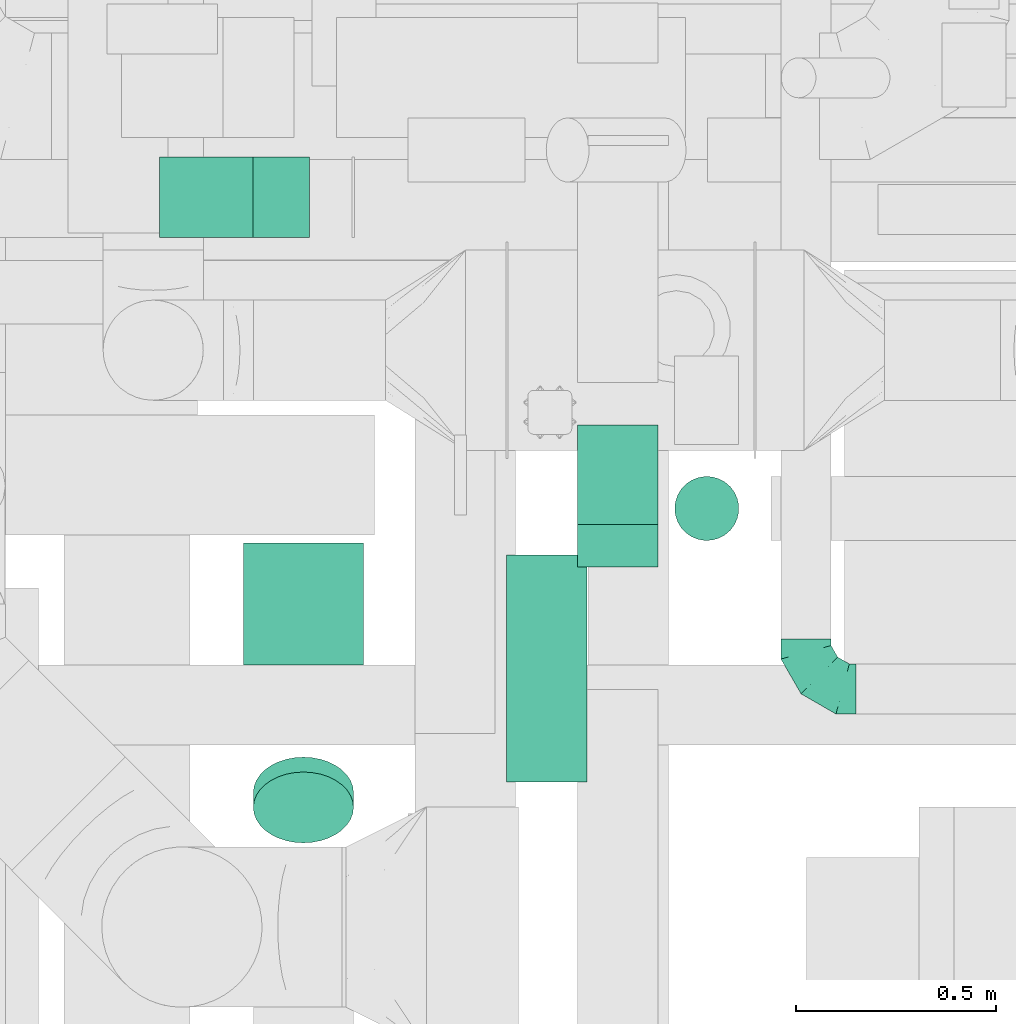
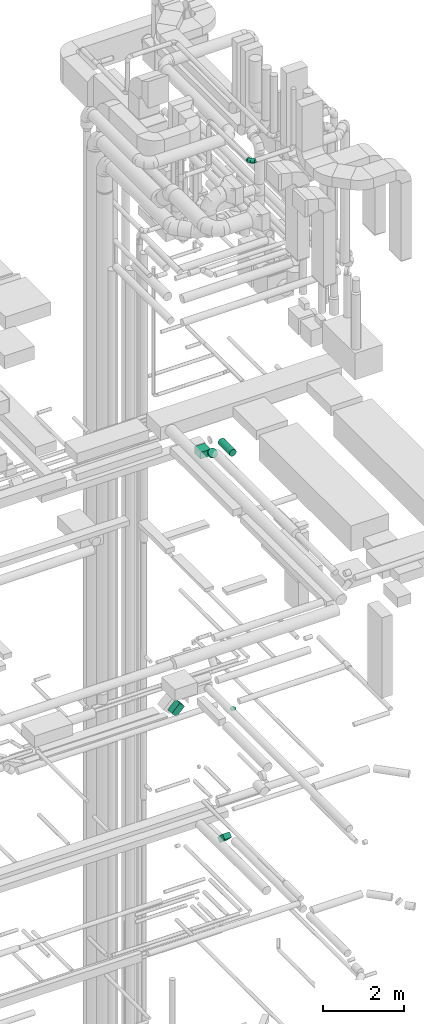
# One storey, part 258 of 337: 6 flow segments, 1 flow fitting.
"""IFC2X3 building model written with IfcOpenShell, lengths in millimetres."""

import ifcopenshell
import ifcopenshell.guid

model = None  # the IFC model being written
_history = None  # IfcOwnerHistory: only IFC2X3 demands one
_inside = {}  # id of a spatial element -> (the spatial element, [elements in it])
_under = {}  # id of a project, library or spatial element -> (it, [spatial elements below it])
_declared = {}  # id of a project -> (the project, [libraries it declares])
_typed = {}  # id of a type object -> (the type object, [elements of that type])
_made_of = {}  # id of a material, layer set ... -> (it, [elements and type objects made of it])


def new_model(schema):
    """Start an empty IFC model of exactly this schema.

    Asked for "IFC4X3", IfcOpenShell would pick the latest addendum, in which some entities
    have other attributes; the version numbers below select the first issue.
    IFC2X3 requires an IfcOwnerHistory on every rooted entity: one is made here for all.
    """
    global model, _history
    if schema == "IFC4X3":
        model = ifcopenshell.file(schema_version=(4, 3, 0, 0))
    else:
        model = ifcopenshell.file(schema=schema)
    _inside.clear()
    _under.clear()
    _declared.clear()
    _typed.clear()
    _made_of.clear()
    _history = None
    if model.schema == "IFC2X3":
        org = make("IfcOrganization", Name="unknown")
        user = make(
            "IfcPersonAndOrganization",
            ThePerson=make("IfcPerson", FamilyName="unknown"),
            TheOrganization=org,
        )
        app = make(
            "IfcApplication",
            ApplicationDeveloper=org,
            Version="unknown",
            ApplicationFullName="unknown",
            ApplicationIdentifier="unknown",
        )
        _history = make(
            "IfcOwnerHistory",
            OwningUser=user,
            OwningApplication=app,
            ChangeAction="ADDED",
            CreationDate=0,
        )
    return model


def make(cls, **values):
    """One entity of the class cls with the attributes given. An attribute that is None is left unset."""
    return model.create_entity(
        cls, **{name: value for name, value in values.items() if value is not None}
    )


def entity(cls, *values):
    """Any entity or typed value of the class cls, its attributes in the order of the schema. None: left unset."""
    e = model.create_entity(cls)
    for i, value in enumerate(values):
        if value is not None:
            e[i] = value
    return e


def rooted(cls, **values):
    """An entity with a GlobalId (a new one), such as an element, a storey or a relation."""
    return make(cls, GlobalId=ifcopenshell.guid.new(), OwnerHistory=_history, **values)


def si_unit(unit_type, name, prefix=None):
    """IfcSIUnit, for example si_unit("LENGTHUNIT", "METRE", prefix="MILLI")."""
    return make("IfcSIUnit", UnitType=unit_type, Prefix=prefix, Name=name)


def converted_unit(unit_type, name, factor, base, dimensions=None, offset=None):
    """IfcConversionBasedUnit, such as the inch: factor (a typed value) times the base unit."""
    return make(
        "IfcConversionBasedUnit"
        if offset is None
        else "IfcConversionBasedUnitWithOffset",
        ConversionOffset=offset,
        Dimensions=None
        if dimensions is None
        else entity("IfcDimensionalExponents", *dimensions),
        UnitType=unit_type,
        Name=name,
        ConversionFactor=make(
            "IfcMeasureWithUnit", ValueComponent=factor, UnitComponent=base
        ),
    )


def derived_unit(unit_type, elements):
    """IfcDerivedUnit: a product of units, each with its exponent."""
    return make(
        "IfcDerivedUnit",
        Elements=[
            make("IfcDerivedUnitElement", Unit=unit, Exponent=power)
            for unit, power in elements
        ],
        UnitType=unit_type,
    )


def assignment(units):
    """IfcUnitAssignment: the units of a project."""
    return None if units is None else make("IfcUnitAssignment", Units=units)


def point(xyz):
    """IfcCartesianPoint."""
    return None if xyz is None else make("IfcCartesianPoint", Coordinates=xyz)


def direction(xyz):
    """IfcDirection."""
    return None if xyz is None else make("IfcDirection", DirectionRatios=xyz)


def frame(location, z_axis=None, x_axis=None):
    """IfcAxis2Placement3D, a coordinate frame: its origin and axes. An axis left out is left unset."""
    return make(
        "IfcAxis2Placement3D",
        Location=point(location),
        Axis=direction(z_axis),
        RefDirection=direction(x_axis),
    )


def frame_2d(location, x_axis=None):
    """IfcAxis2Placement2D, a coordinate frame in the plane: its origin and x axis."""
    return make(
        "IfcAxis2Placement2D", Location=point(location), RefDirection=direction(x_axis)
    )


def origin():
    """The frame at (0, 0, 0) with its axes left unset."""
    return frame((0.0, 0.0, 0.0))


def origin_2d_with_axis():
    """The frame at (0, 0) in the plane with the x axis (1, 0) written out."""
    return frame_2d((0.0, 0.0), x_axis=(1.0, 0.0))


def place(relative_to, where):
    """IfcLocalPlacement: puts the frame where relative to a parent placement (None: the world)."""
    return make(
        "IfcLocalPlacement", PlacementRelTo=relative_to, RelativePlacement=where
    )


def context(
    kind, dimensions, precision=None, world=None, true_north=None, identifier=None
):
    """IfcGeometricRepresentationContext, for example the 3D "Model" context."""
    return make(
        "IfcGeometricRepresentationContext",
        ContextIdentifier=identifier,
        ContextType=kind,
        CoordinateSpaceDimension=dimensions,
        Precision=precision,
        WorldCoordinateSystem=world,
        TrueNorth=true_north,
    )


def subcontext(parent, identifier, kind, view, scale=None):
    """IfcGeometricRepresentationSubContext, for example "Body" below "Model"."""
    return make(
        "IfcGeometricRepresentationSubContext",
        ContextIdentifier=identifier,
        ContextType=kind,
        ParentContext=parent,
        TargetScale=scale,
        TargetView=view,
    )


def project(units=None, contexts=None):
    """IfcProject with its units and contexts."""
    return rooted(
        "IfcProject",
        Name="project",
        RepresentationContexts=contexts,
        UnitsInContext=assignment(units),
    )


def spatial(cls, under=None, at=None, **own):
    """A site, building, storey or space (cls), placed at a placement, below another one or the project."""
    s = rooted(cls, ObjectPlacement=at, **own)
    if under is not None:
        _under.setdefault(under.id(), (under, []))[1].append(s)
    return s


def profile(cls, at=None, kind="AREA", **sizes):
    """A parametric profile (cls). Its sizes go by their IFC names, for example OverallWidth=200.0."""
    return make(cls, ProfileType=kind, Position=at, **sizes)


def rectangle(**sizes):
    """IfcRectangleProfileDef."""
    return profile("IfcRectangleProfileDef", **sizes)


def circle(**sizes):
    """IfcCircleProfileDef."""
    return profile("IfcCircleProfileDef", **sizes)


def extrude(swept, where, along, depth):
    """IfcExtrudedAreaSolid: the profile swept, set in the frame where, extruded along a direction by depth."""
    return make(
        "IfcExtrudedAreaSolid",
        SweptArea=swept,
        Position=where,
        ExtrudedDirection=direction(along),
        Depth=depth,
    )


def faces_of(points, faces, orient=None, outer=None):
    """IfcFace entities. A face is a list of loops; a loop is a list of indices into points, from 0.

    orient and outer hold one flag for each loop. By default every Orientation is true, the
    first loop of a face is its IfcFaceOuterBound and the others are IfcFaceBound.
    """
    made = []
    for i, loops in enumerate(faces):
        bounds = []
        for j, loop in enumerate(loops):
            is_outer = j == 0 if outer is None else outer[i][j]
            bounds.append(
                make(
                    "IfcFaceOuterBound" if is_outer else "IfcFaceBound",
                    Bound=make("IfcPolyLoop", Polygon=[points[k] for k in loop]),
                    Orientation=True if orient is None else orient[i][j],
                )
            )
        made.append(make("IfcFace", Bounds=bounds))
    return made


def faceted_brep(points, faces, orient=None, outer=None, voids=None):
    """IfcFacetedBrep: a solid bounded by flat faces; with voids (closed shells), ...WithVoids."""
    shared = [point(p) for p in points]
    hull = make("IfcClosedShell", CfsFaces=faces_of(shared, faces, orient, outer))
    if voids is None:
        return make("IfcFacetedBrep", Outer=hull)
    return make(
        "IfcFacetedBrepWithVoids",
        Outer=hull,
        Voids=[
            make(cls, CfsFaces=faces_of(shared, fs, o, b)) for cls, fs, o, b in voids
        ],
    )


def shape(context_of_items, identifier, shape_type, items):
    """IfcShapeRepresentation: the items that make up one representation, for example the "Body"."""
    return make(
        "IfcShapeRepresentation",
        ContextOfItems=context_of_items,
        RepresentationIdentifier=identifier,
        RepresentationType=shape_type,
        Items=items,
    )


def source(mapping_origin, context_of_items, identifier, shape_type, items):
    """IfcRepresentationMap: a shape defined once, which mapped items show again and again."""
    return make(
        "IfcRepresentationMap",
        MappingOrigin=mapping_origin,
        MappedRepresentation=shape(context_of_items, identifier, shape_type, items),
    )


def transform(
    local_origin,
    x_axis=None,
    y_axis=None,
    z_axis=None,
    scale=None,
    scale2=None,
    scale3=None,
    uniform=True,
):
    """IfcCartesianTransformationOperator3D, or its non-uniform kind. x_axis, y_axis, z_axis: its Axis1, 2, 3."""
    if uniform:
        return make(
            "IfcCartesianTransformationOperator3D",
            Axis1=direction(x_axis),
            Axis2=direction(y_axis),
            LocalOrigin=point(local_origin),
            Scale=scale,
            Axis3=direction(z_axis),
        )
    return make(
        "IfcCartesianTransformationOperator3DnonUniform",
        Axis1=direction(x_axis),
        Axis2=direction(y_axis),
        LocalOrigin=point(local_origin),
        Scale=scale,
        Axis3=direction(z_axis),
        Scale2=scale2,
        Scale3=scale3,
    )


def mapped(mapping_source, mapping_target):
    """IfcMappedItem: shows the shape of a source again, moved by a transform."""
    return make(
        "IfcMappedItem", MappingSource=mapping_source, MappingTarget=mapping_target
    )


def material(Name=None, Category=None):
    """IfcMaterial."""
    return make("IfcMaterial", Name=Name, Category=Category)


def made_of(thing, what):
    """Note that an element or type object is made of a material, layer set ...; save() writes the relation."""
    if what is not None:
        _made_of.setdefault(what.id(), (what, []))[1].append(thing)
    return thing


def type_object(cls, material=None, **own):
    """A type object (cls), such as IfcWallType, which elements share."""
    return made_of(rooted(cls, **own), material)


def type_shapes(of_type, sources):
    """Give a type object the sources (RepresentationMaps) that its elements show as mapped items."""
    of_type.RepresentationMaps = sources


def element(
    cls,
    number,
    at=None,
    inside=None,
    cuts=None,
    type_object=None,
    material=None,
    context=None,
    identifier="Body",
    shape_type=None,
    held_by="IfcProductDefinitionShape",
    body=None,
    shapes=None,
    **own,
):
    """One element of the class cls, such as IfcWall. Its Tag is "e" and its number.

    at: its placement. inside: the storey or other place that contains it. cuts: it is an
    opening in that element (IfcRelVoidsElement). A single representation is given by context,
    identifier, shape_type and body (its items); several are given by shapes. held_by: the class
    of the entity that holds the representations. save() writes the other relations.
    """
    e = rooted(cls, Tag="e%d" % number, ObjectPlacement=at, **own)
    if body is not None:
        shapes = [shape(context, identifier, shape_type, body)]
    if shapes is not None:
        e.Representation = make(held_by, Representations=shapes)
    if inside is not None:
        _inside.setdefault(inside.id(), (inside, []))[1].append(e)
    if cuts is not None:
        rooted(
            "IfcRelVoidsElement", RelatingBuildingElement=cuts, RelatedOpeningElement=e
        )
    if type_object is not None:
        _typed.setdefault(type_object.id(), (type_object, []))[1].append(e)
    return made_of(e, material)


def aggregate(whole, parts):
    """IfcRelAggregates: a whole, such as a stair, and the parts it consists of."""
    return rooted("IfcRelAggregates", RelatingObject=whole, RelatedObjects=parts)


def save(model, path):
    """Write the relations noted so far, then the file.

    IfcRelAggregates (storeys below a building ...), IfcRelContainedInSpatialStructure (elements
    in a storey), IfcRelDefinesByType, IfcRelAssociatesMaterial and IfcRelDeclares: one each for
    every whole, place, type object, material and project.
    """
    for whole, parts in _under.values():
        aggregate(whole, parts)
    for where, things in _inside.values():
        rooted(
            "IfcRelContainedInSpatialStructure",
            RelatedElements=things,
            RelatingStructure=where,
        )
    for kind, things in _typed.values():
        rooted("IfcRelDefinesByType", RelatedObjects=things, RelatingType=kind)
    for what, things in _made_of.values():
        rooted("IfcRelAssociatesMaterial", RelatedObjects=things, RelatingMaterial=what)
    for by, libraries in _declared.values():
        rooted("IfcRelDeclares", RelatingContext=by, RelatedDefinitions=libraries)
    model.write(path)


model = new_model("IFC2X3")

# Units and contexts
model_context = context("Model", 3, precision=0.01, world=origin(), true_north=direction((6.12303176911189e-17, 1.0)))
body_context = subcontext(model_context, "Body", "Model", "MODEL_VIEW")
ifc_project = project(units=[si_unit("LENGTHUNIT", "METRE", prefix="MILLI"), si_unit("AREAUNIT", "SQUARE_METRE"), si_unit("VOLUMEUNIT", "CUBIC_METRE"), converted_unit("PLANEANGLEUNIT", "DEGREE", entity("IfcRatioMeasure", 0.0174532925199433), si_unit("PLANEANGLEUNIT", "RADIAN"), dimensions=[0, 0, 0, 0, 0, 0, 0]), si_unit("MASSUNIT", "GRAM", prefix="KILO"), derived_unit("MASSDENSITYUNIT", [(si_unit("MASSUNIT", "GRAM", prefix="KILO"), 1), (si_unit("LENGTHUNIT", "METRE"), -3)]), derived_unit("MOMENTOFINERTIAUNIT", [(si_unit("LENGTHUNIT", "METRE"), 4)]), si_unit("TIMEUNIT", "SECOND"), si_unit("FREQUENCYUNIT", "HERTZ"), si_unit("THERMODYNAMICTEMPERATUREUNIT", "DEGREE_CELSIUS"), derived_unit("THERMALTRANSMITTANCEUNIT", [(si_unit("MASSUNIT", "GRAM", prefix="KILO"), 1), (si_unit("THERMODYNAMICTEMPERATUREUNIT", "KELVIN"), -1), (si_unit("TIMEUNIT", "SECOND"), -3)]), derived_unit("VOLUMETRICFLOWRATEUNIT", [(si_unit("LENGTHUNIT", "METRE"), 3), (si_unit("TIMEUNIT", "SECOND"), -1)]), derived_unit("MASSFLOWRATEUNIT", [(si_unit("MASSUNIT", "GRAM", prefix="KILO"), 1), (si_unit("TIMEUNIT", "SECOND"), -1)]), derived_unit("ROTATIONALFREQUENCYUNIT", [(si_unit("TIMEUNIT", "SECOND"), -1)]), si_unit("ELECTRICCURRENTUNIT", "AMPERE"), si_unit("ELECTRICVOLTAGEUNIT", "VOLT"), si_unit("POWERUNIT", "WATT"), si_unit("FORCEUNIT", "NEWTON", prefix="KILO"), si_unit("ILLUMINANCEUNIT", "LUX"), si_unit("LUMINOUSFLUXUNIT", "LUMEN"), si_unit("LUMINOUSINTENSITYUNIT", "CANDELA"), derived_unit("USERDEFINED", [(si_unit("MASSUNIT", "GRAM", prefix="KILO"), -1), (si_unit("LENGTHUNIT", "METRE"), -2), (si_unit("TIMEUNIT", "SECOND"), 3), (si_unit("LUMINOUSFLUXUNIT", "LUMEN"), 1)]), derived_unit("LINEARVELOCITYUNIT", [(si_unit("LENGTHUNIT", "METRE"), 1), (si_unit("TIMEUNIT", "SECOND"), -1)]), si_unit("PRESSUREUNIT", "PASCAL"), derived_unit("USERDEFINED", [(si_unit("LENGTHUNIT", "METRE"), -2), (si_unit("MASSUNIT", "GRAM", prefix="KILO"), 1), (si_unit("TIMEUNIT", "SECOND"), -2)]), derived_unit("LINEARFORCEUNIT", [(si_unit("MASSUNIT", "GRAM", prefix="KILO"), 1), (si_unit("LENGTHUNIT", "METRE"), 1), (si_unit("TIMEUNIT", "SECOND"), -2), (si_unit("LENGTHUNIT", "METRE"), -1)]), derived_unit("PLANARFORCEUNIT", [(si_unit("MASSUNIT", "GRAM", prefix="KILO"), 1), (si_unit("LENGTHUNIT", "METRE"), 1), (si_unit("TIMEUNIT", "SECOND"), -2), (si_unit("LENGTHUNIT", "METRE"), -2)])], contexts=[model_context])

# Site, building, storey
site_placement = place(None, origin())
site = spatial("IfcSite", under=ifc_project, at=site_placement, CompositionType="ELEMENT")
building_placement = place(site_placement, origin())
building = spatial("IfcBuilding", under=site, at=building_placement, CompositionType="ELEMENT")
storey_placement = place(building_placement, origin())
storey = spatial("IfcBuildingStorey", under=building, at=storey_placement, CompositionType="ELEMENT", Elevation=0.0)

# Flow segments
duct_segment_type_1 = type_object("IfcDuctSegmentType", PredefinedType="NOTDEFINED")
flow_segment_1_placement = place(storey_placement, frame((69187.53, 8653.16, 14982.87)))
element("IfcFlowSegment", 1, at=flow_segment_1_placement, inside=storey, type_object=duct_segment_type_1, context=body_context, shape_type="SweptSolid", body=[
    extrude(rectangle(XDim=149.999999999999, YDim=351.005050633926, at=frame_2d((0.0, 0.0), x_axis=(0.0, 1.0))), frame((0.0, 177.13, 177.13), z_axis=(1.0, 0.0, 0.0), x_axis=(0.0, 0.707106781186549, -0.707106781186546)), (0.0, 0.0, 1.0), 200.000000000007),
])
flow_segment_2_placement = place(storey_placement, frame((68143.46, 9475.53, 18772.51)))
element("IfcFlowSegment", 2, at=flow_segment_2_placement, inside=storey, type_object=duct_segment_type_1, context=body_context, shape_type="SweptSolid", body=[
    extrude(rectangle(XDim=200.000000000003, YDim=200.0, at=origin_2d_with_axis()), frame((70.71, 100.0, 70.71), z_axis=(0.707106781186537, 0.0, 0.707106781186558), x_axis=(-0.707106781186558, 0.0, 0.707106781186537)), (0.0, 0.0, 1.0), 330.294372515211),
])
flow_segment_3_placement = place(storey_placement, frame((68353.02, 8407.74, 27200.0)))
element("IfcFlowSegment", 3, at=flow_segment_3_placement, inside=storey, type_object=duct_segment_type_1, context=body_context, shape_type="SweptSolid", body=[
    extrude(rectangle(XDim=304.666377406726, YDim=300.000000000001, at=origin_2d_with_axis()), frame((150.0, 152.33, 0.0), z_axis=(0.0, 0.0, 1.0), x_axis=(0.0, -1.0, 0.0)), (0.0, 0.0, 1.0), 199.999999999998),
])
duct_segment_type_2 = type_object("IfcDuctSegmentType", PredefinedType="NOTDEFINED")
flow_segment_4_placement = place(storey_placement, frame((69428.24, 8716.98, 18995.0)))
element("IfcFlowSegment", 4, at=flow_segment_4_placement, inside=storey, type_object=duct_segment_type_2, context=body_context, shape_type="SweptSolid", body=[
    extrude(circle(Radius=80.0, at=origin_2d_with_axis()), frame((81.6, 81.6, 0.0), z_axis=(0.0, 0.0, 1.0), x_axis=(-1.0, 0.0, 0.0)), (0.0, 0.0, 1.0), 10.0000000000151),
])
flow_segment_5_placement = place(storey_placement, frame((69008.92, 8116.53, 27198.4)))
element("IfcFlowSegment", 5, at=flow_segment_5_placement, inside=storey, type_object=duct_segment_type_2, context=body_context, shape_type="SweptSolid", body=[
    extrude(circle(Radius=100.0, at=origin_2d_with_axis()), frame((101.6, 0.0, 101.6), z_axis=(0.0, 1.0, 0.0), x_axis=(-1.0, 0.0, 0.0)), (0.0, 0.0, 1.0), 565.879708967236),
])
flow_segment_6_placement = place(storey_placement, frame((68376.42, 7962.43, 27424.66)))
element("IfcFlowSegment", 6, at=flow_segment_6_placement, inside=storey, type_object=duct_segment_type_2, context=body_context, shape_type="SweptSolid", body=[
    extrude(circle(Radius=125.0, at=origin_2d_with_axis()), frame((126.6, 89.98, 127.12), z_axis=(0.0, 0.707106781186549, -0.707106781186546), x_axis=(-1.0, 0.0, 0.0)), (0.0, 0.0, 1.0), 52.5126265847517),
])

# Flow fitting
ifc_material = material()
duct_fitting_type = type_object("IfcDuctFittingType", PredefinedType="NOTDEFINED", material=ifc_material)
shared_shape = source(origin(), body_context, "Body", "Brep", [
    faceted_brep([(-125.0, 0.0, -62.5), (-125.0, -16.18, -60.37), (-125.0, -31.25, -54.13), (-125.0, -44.19, -44.19), (-125.0, -54.13, -31.25), (-125.0, -60.37, -16.18), (-125.0, -62.5, 0.0), (-125.0, -60.37, 16.18), (-125.0, -54.13, 31.25), (-125.0, -44.19, 44.19), (-125.0, -31.25, 54.13), (-125.0, -16.18, 60.37), (-125.0, 0.0, 62.5), (-125.0, 16.18, 60.37), (-125.0, 31.25, 54.13), (-125.0, 44.19, 44.19), (-125.0, 54.13, 31.25), (-125.0, 60.37, 16.18), (-125.0, 62.5, 0.0), (-125.0, 60.37, -16.18), (-125.0, 54.13, -31.25), (-125.0, 44.19, -44.19), (-125.0, 31.25, -54.13), (-125.0, 16.18, -60.37), (-95.84, 16.18, 60.37), (-99.88, 31.25, 54.13), (-91.51, 0.0, 62.5), (-103.35, 44.19, 44.19), (-107.68, 60.37, 16.18), (-108.25, 62.5, 0.0), (-106.01, 54.13, 31.25), (-106.01, 54.13, -31.25), (-103.35, 44.19, -44.19), (-107.68, 60.37, -16.18), (-95.84, 16.18, -60.37), (-91.51, 0.0, -62.5), (-99.88, 31.25, -54.13), (-87.17, -16.18, -60.37), (-83.13, -31.25, -54.13), (-79.66, -44.19, -44.19), (-77.0, -54.13, -31.25), (-75.33, -60.37, -16.18), (-74.76, -62.5, 0.0), (-75.33, -60.37, 16.18), (-77.0, -54.13, 31.25), (-79.66, -44.19, 44.19), (-83.13, -31.25, 54.13), (-87.17, -16.18, 60.37), (-45.34, 45.34, 60.37), (-56.37, 56.37, 54.13), (-33.49, 33.49, 62.5), (-65.85, 65.85, 44.19), (-73.12, 73.12, 31.25), (-77.69, 77.69, 16.18), (-79.25, 79.25, 0.0), (-77.69, 77.69, -16.18), (-73.12, 73.12, -31.25), (-65.85, 65.85, -44.19), (-45.34, 45.34, -60.37), (-33.49, 33.49, -62.5), (-56.37, 56.37, -54.13), (-21.65, 21.65, -60.37), (-10.62, 10.62, -54.13), (-1.14, 1.14, -44.19), (6.13, -6.13, -31.25), (10.7, -10.7, -16.18), (12.26, -12.26, 0.0), (10.7, -10.7, 16.18), (6.13, -6.13, 31.25), (-1.14, 1.14, 44.19), (-10.62, 10.62, 54.13), (-21.65, 21.65, 60.37), (-16.18, 95.84, 60.37), (-31.25, 99.88, 54.13), (0.0, 91.51, 62.5), (-44.19, 103.35, 44.19), (-54.13, 106.01, 31.25), (-60.37, 107.68, 16.18), (-62.5, 108.25, 0.0), (-60.37, 107.68, -16.18), (-54.13, 106.01, -31.25), (-44.19, 103.35, -44.19), (-16.18, 95.84, -60.37), (0.0, 91.51, -62.5), (-31.25, 99.88, -54.13), (16.18, 87.17, -60.37), (31.25, 83.13, -54.13), (44.19, 79.66, -44.19), (54.13, 77.0, -31.25), (60.37, 75.33, -16.18), (62.5, 74.76, 0.0), (60.37, 75.33, 16.18), (54.13, 77.0, 31.25), (44.19, 79.66, 44.19), (31.25, 83.13, 54.13), (16.18, 87.17, 60.37), (-16.18, 125.0, -60.37), (-31.25, 125.0, -54.13), (-44.19, 125.0, -44.19), (-54.13, 125.0, -31.25), (-60.37, 125.0, -16.18), (-62.5, 125.0, 0.0), (-60.37, 125.0, 16.18), (-54.13, 125.0, 31.25), (-44.19, 125.0, 44.19), (-31.25, 125.0, 54.13), (-16.18, 125.0, 60.37), (0.0, 125.0, 62.5), (16.18, 125.0, 60.37), (31.25, 125.0, 54.13), (44.19, 125.0, 44.19), (54.13, 125.0, 31.25), (60.37, 125.0, 16.18), (62.5, 125.0, 0.0), (60.37, 125.0, -16.18), (54.13, 125.0, -31.25), (44.19, 125.0, -44.19), (31.25, 125.0, -54.13), (16.18, 125.0, -60.37), (0.0, 125.0, -62.5)], [[[0, 1, 2, 3, 4, 5, 6, 7, 8, 9, 10, 11, 12, 13, 14, 15, 16, 17, 18, 19, 20, 21, 22, 23]], [[24, 25, 14, 13]], [[26, 24, 13, 12]], [[14, 25, 27, 15]], [[28, 29, 18, 17]], [[30, 28, 17, 16]], [[15, 27, 30, 16]], [[20, 31, 32, 21]], [[33, 31, 20, 19]], [[18, 29, 33, 19]], [[34, 35, 0, 23]], [[36, 34, 23, 22]], [[21, 32, 36, 22]], [[1, 0, 35, 37]], [[2, 1, 37, 38]], [[38, 39, 3, 2]], [[5, 4, 40, 41]], [[6, 5, 41, 42]], [[39, 40, 4, 3]], [[6, 42, 43, 7]], [[7, 43, 44, 8]], [[45, 9, 8, 44]], [[9, 45, 46, 10]], [[10, 46, 47, 11]], [[26, 12, 11, 47]], [[48, 49, 25, 24]], [[50, 48, 24, 26]], [[27, 25, 49, 51]], [[52, 53, 28, 30]], [[51, 52, 30, 27]], [[29, 28, 53, 54]], [[55, 56, 31, 33]], [[54, 55, 33, 29]], [[57, 32, 31, 56]], [[58, 59, 35, 34]], [[60, 58, 34, 36]], [[57, 60, 36, 32]], [[37, 35, 59, 61]], [[38, 37, 61, 62]], [[39, 38, 62, 63]], [[41, 40, 64, 65]], [[42, 41, 65, 66]], [[63, 64, 40, 39]], [[43, 42, 66, 67]], [[44, 43, 67, 68]], [[68, 69, 45, 44]], [[46, 45, 69, 70]], [[47, 46, 70, 71]], [[26, 47, 71, 50]], [[72, 73, 49, 48]], [[74, 72, 48, 50]], [[51, 49, 73, 75]], [[76, 77, 53, 52]], [[75, 76, 52, 51]], [[54, 53, 77, 78]], [[79, 80, 56, 55]], [[78, 79, 55, 54]], [[81, 57, 56, 80]], [[82, 83, 59, 58]], [[84, 82, 58, 60]], [[81, 84, 60, 57]], [[61, 59, 83, 85]], [[62, 61, 85, 86]], [[63, 62, 86, 87]], [[65, 64, 88, 89]], [[66, 65, 89, 90]], [[87, 88, 64, 63]], [[67, 66, 90, 91]], [[68, 67, 91, 92]], [[92, 93, 69, 68]], [[70, 69, 93, 94]], [[71, 70, 94, 95]], [[50, 71, 95, 74]], [[96, 97, 98, 99, 100, 101, 102, 103, 104, 105, 106, 107, 108, 109, 110, 111, 112, 113, 114, 115, 116, 117, 118, 119]], [[72, 74, 107, 106]], [[73, 72, 106, 105]], [[75, 73, 105, 104]], [[77, 76, 103, 102]], [[78, 77, 102, 101]], [[75, 104, 103, 76]], [[78, 101, 100, 79]], [[79, 100, 99, 80]], [[80, 99, 98, 81]], [[96, 119, 83, 82]], [[97, 96, 82, 84]], [[84, 81, 98, 97]], [[83, 119, 118, 85]], [[85, 118, 117, 86]], [[116, 87, 86, 117]], [[88, 115, 114, 89]], [[89, 114, 113, 90]], [[115, 88, 87, 116]], [[91, 90, 113, 112]], [[92, 91, 112, 111]], [[111, 110, 93, 92]], [[95, 94, 109, 108]], [[74, 95, 108, 107]], [[110, 109, 94, 93]]]),
])
type_shapes(duct_fitting_type, [shared_shape])
flow_fitting_placement = place(storey_placement, frame((69757.45, 8348.12, 35750.0), z_axis=(0.0, 0.0, 1.0), x_axis=(0.0, -1.0, 0.0)))
element("IfcFlowFitting", 7, at=flow_fitting_placement, inside=storey, type_object=duct_fitting_type, material=ifc_material, context=body_context, shape_type="MappedRepresentation", body=[
    mapped(shared_shape, transform((0.0, 0.0, 0.0), scale=1.0)),
])

save(model, "model.ifc")
